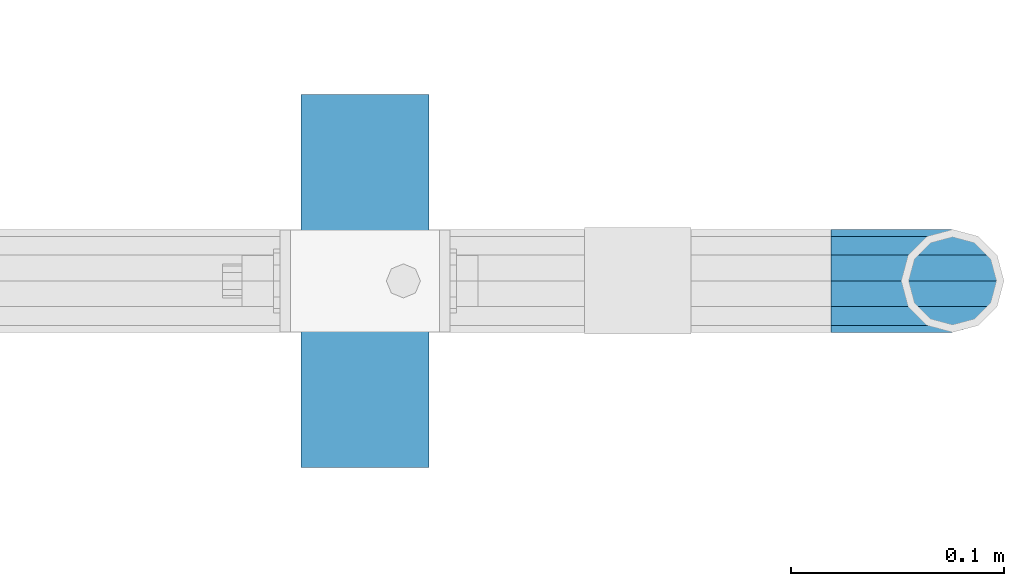
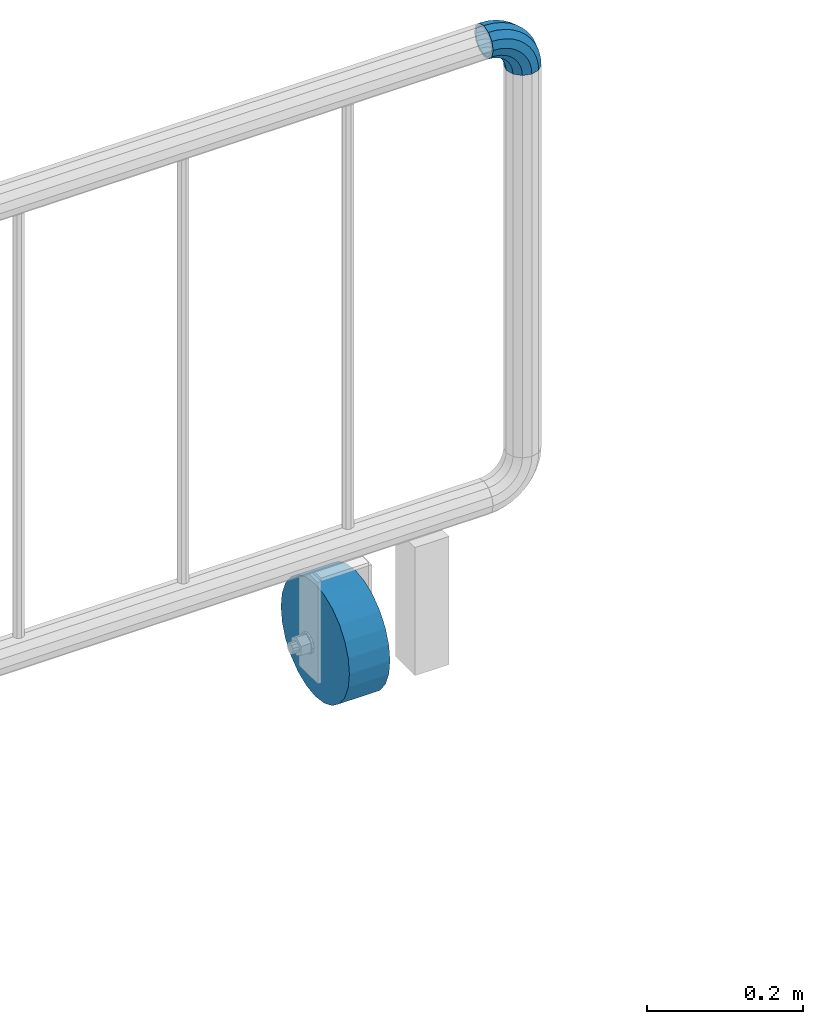
# One storey, part 152 of 208: 1 beam, 1 member.
"""IFC2X3 building model written with IfcOpenShell, lengths in millimetres."""

from ifc_helpers import new_model, si_unit, frame, origin_with_axes, place, context, subcontext, project, spatial, faceted_brep, material, type_object, element, save


model = new_model("IFC2X3")

# Units and contexts
model_context = context("Model", 3, precision=1e-05, world=origin_with_axes())
body_context = subcontext(model_context, "Body", "Model", "MODEL_VIEW")
ifc_project = project(units=[si_unit("LENGTHUNIT", "METRE", prefix="MILLI"), si_unit("AREAUNIT", "SQUARE_METRE"), si_unit("VOLUMEUNIT", "CUBIC_METRE"), si_unit("MASSUNIT", "GRAM", prefix="KILO"), si_unit("TIMEUNIT", "SECOND"), si_unit("PLANEANGLEUNIT", "RADIAN"), si_unit("SOLIDANGLEUNIT", "STERADIAN"), si_unit("THERMODYNAMICTEMPERATUREUNIT", "DEGREE_CELSIUS"), si_unit("LUMINOUSINTENSITYUNIT", "LUMEN")], contexts=[model_context])

# Site, building, storey
site_placement = place(None, origin_with_axes())
site = spatial("IfcSite", under=ifc_project, at=site_placement, CompositionType="ELEMENT")
building_placement = place(site_placement, origin_with_axes())
building = spatial("IfcBuilding", under=site, at=building_placement, Name="Standard", CompositionType="ELEMENT")
storey_placement = place(building_placement, origin_with_axes())
storey = spatial("IfcBuildingStorey", under=building, at=storey_placement, Name="Undefined", CompositionType="ELEMENT", Elevation=0.0)

# Member
ifc_material_1 = material()
member_type = type_object("IfcMemberType", PredefinedType="NOTDEFINED")
member_placement = place(storey_placement, frame((-12177.0539762199, 5941.85399999618, 935.350000000009), z_axis=(0.0, -1.0, 0.0), x_axis=(0.707106781186548, 0.0, -0.707106781186548)))
element("IfcMember", 1, at=member_placement, inside=storey, type_object=member_type, material=ifc_material_1, context=body_context, shape_type="Brep", body=[
    faceted_brep([(17.0766287656552, -17.0766287656552, 0.0), (14.7887943220539, -14.7887943220539, -12.0749999999998), (19.0945697419538, -11.1113146999724, -12.0749999999998), (20.9963409898282, -13.7288782624146, 0.0), (8.53831438282759, -8.53831438282759, -20.9145135013941), (13.8988340683954, -3.95999805533756, -20.9145135013941), (0.0, 0.0, -24.1500000000001), (6.80132714696265, 5.80888215173945, -24.1500000000001), (-8.53831438282759, 8.53831438282759, -20.9145135013941), (-0.296179774470147, 15.5777623588165, -20.9145135013941), (-14.7887943220521, 14.7887943220521, -12.0749999999998), (-5.49191544802852, 22.7290790034513, -12.0749999999998), (-17.0766287656552, 17.0766287656552, 0.0), (-7.39368669589931, 25.3466425658935, 0.0), (-14.7887943220521, 14.7887943220521, 12.0749999999998), (-5.49191544802852, 22.7290790034513, 12.0749999999998), (-8.53831438282759, 8.53831438282759, 20.9145135013941), (-0.296179774470147, 15.5777623588165, 20.9145135013941), (0.0, 0.0, 24.1500000000001), (6.80132714696265, 5.80888215173945, 24.1500000000001), (8.53831438282759, -8.53831438282759, 20.9145135013941), (13.8988340683954, -3.95999805533756, 20.9145135013941), (14.7887943220539, -14.7887943220539, 12.0749999999998), (19.0945697419538, -11.1113146999724, 12.0749999999998), (14.5310443533836, -14.5310443533836, 0.0), (12.5842535535485, -12.5842535535485, 10.2750000000001), (17.2620366843166, -8.58904933077247, 10.2750000000001), (18.8803140815726, -10.8164170826676, 0.0), (7.26552217669268, -7.26552217669268, 17.7968220477701), (12.8408206142685, -2.50376746546499, 17.7968220477701), (0.0, 0.0, 20.5500000000002), (6.80132714696265, 5.80888215173945, 20.5500000000002), (-7.26552217669087, 7.26552217669087, 17.7968220477701), (0.761833679658594, 14.1215317689421, 17.7968220477701), (-12.5842535535485, 12.5842535535485, 10.2750000000001), (-3.65938239039133, 20.2068136342514, 10.2750000000001), (-14.5310443533836, 14.5310443533836, 0.0), (-5.27765978764546, 22.4341813861447, 0.0), (-12.5842535535485, 12.5842535535485, -10.2750000000001), (-3.65938239039133, 20.2068136342514, -10.2750000000001), (-7.26552217669087, 7.26552217669087, -17.7968220477701), (0.761833679658594, 14.1215317689421, -17.7968220477701), (0.0, 0.0, -20.5500000000002), (6.80132714696265, 5.80888215173945, -20.5500000000002), (7.26552217669268, -7.26552217669268, -17.7968220477701), (12.8408206142685, -2.50376746546499, -17.7968220477701), (12.5842535535485, -12.5842535535485, -10.2750000000001), (17.2620366843166, -8.58904933077247, -10.2750000000001), (23.9226184787876, -8.15268262886457, -12.0749999999998), (25.3914986111904, -11.0355222080452, 0.0), (19.9095633268353, -0.27661842847192, -20.9145135013941), (14.4276280424801, 10.482285351105, -24.1500000000001), (8.94569275812501, 21.2411891306783, -20.9145135013941), (4.93263760617265, 29.117253331071, -12.0749999999998), (3.46375747377169, 32.0000929102534, 0.0), (4.93263760617265, 29.117253331071, 12.0749999999998), (8.94569275812501, 21.2411891306783, 20.9145135013941), (14.4276280424801, 10.482285351105, 24.1500000000001), (19.9095633268353, -0.27661842847192, 20.9145135013941), (23.9226184787876, -8.15268262886457, 12.0749999999998), (22.5072161777225, -5.3747992032786, 10.2750000000001), (23.7571328121267, -7.82789872096691, 0.0), (19.0923804273043, 1.32719331506814, 17.7968220477701), (14.4276280424801, 10.482285351105, 20.5500000000002), (9.76287565765597, 19.6373773871383, 17.7968220477701), (6.34803990723776, 26.3393699054886, 10.2750000000001), (5.0981232728318, 28.7924694231751, 0.0), (6.34803990723776, 26.3393699054886, -10.2750000000001), (9.76287565765597, 19.6373773871383, -17.7968220477701), (14.4276280424801, 10.482285351105, -20.5500000000002), (19.0923804273043, 1.32719331506814, -17.7968220477701), (22.5072161777225, -5.3747992032786, -10.2750000000001), (29.1540579492776, -5.98574944945176, -12.0749999999998), (30.1538782624175, -9.06287996733772, 0.0), (26.422498055339, 2.42112746692692, -20.9145135013941), (22.6911178482624, 13.9051349011897, -24.1500000000001), (18.9597376411857, 25.3891423354562, -20.9145135013941), (16.2281777472472, 33.7960192518349, -12.0749999999998), (15.2283574341091, 36.873149769719, 0.0), (16.2281777472472, 33.7960192518349, 12.0749999999998), (18.9597376411857, 25.3891423354562, 20.9145135013941), (22.6911178482624, 13.9051349011897, 24.1500000000001), (26.422498055339, 2.42112746692692, 20.9145135013941), (29.1540579492776, -5.98574944945176, 12.0749999999998), (28.1906383068908, -3.0206486766856, 10.2750000000001), (29.041417082668, -5.63907650867441, 0.0), (25.8662674654661, 4.13302919625858, 17.7968220477701), (22.6911178482624, 13.9051349011897, 20.5500000000002), (19.5159682310605, 23.6772406061227, 17.7968220477701), (17.1915973896339, 30.8309184790687, 10.2750000000001), (16.3408186138568, 33.4493463110575, 0.0), (17.1915973896339, 30.8309184790687, -10.2750000000001), (19.5159682310605, 23.6772406061227, -17.7968220477701), (22.6911178482624, 13.9051349011897, -20.5500000000002), (25.8662674654661, 4.13302919625858, -17.7968220477701), (28.1906383068908, -3.0206486766856, -10.2750000000001), (34.660072751507, -4.66387224825667, -12.0749999999998), (35.1662143510621, -7.85952453908249, 0.0), (33.2772681857005, 4.06681217360347, -20.9145135013941), (31.3883220203406, 15.9931488862876, -24.1500000000001), (29.4993758549808, 27.9194855989754, -20.9145135013941), (28.1165712891743, 36.6501700208355, -12.0749999999998), (27.6104296896192, 39.8458223116613, 0.0), (28.1165712891743, 36.6501700208355, 12.0749999999998), (29.4993758549808, 27.9194855989754, 20.9145135013941), (31.3883220203406, 15.9931488862876, 24.1500000000001), (33.2772681857005, 4.06681217360347, 20.9145135013941), (34.660072751507, -4.66387224825667, 12.0749999999998), (34.1723583568, -1.58456474993909, 10.2750000000001), (34.6030502769172, -4.30384651293934, 0.0), (32.995686148628, 5.84465118667504, 17.7968220477701), (31.3883220203406, 15.9931488862876, 20.5500000000002), (29.7809578920533, 26.1416465859038, 17.7968220477701), (28.6042856838831, 33.5708625225197, 10.2750000000001), (28.1735937637659, 36.29014428552, 0.0), (28.6042856838831, 33.5708625225197, -10.2750000000001), (29.7809578920533, 26.1416465859038, -17.7968220477701), (31.3883220203406, 15.9931488862876, -20.5500000000002), (32.995686148628, 5.84465118667504, -17.7968220477701), (34.1723583568, -1.58456474993909, -10.2750000000001), (40.3050865276346, -4.21960002902779, -12.0749999999998), (40.3050865276346, -7.45508652763237, 0.0), (40.3050865276327, 4.61991347236653, -20.9145135013941), (40.3050865276327, 16.6949134723673, -24.1500000000001), (40.3050865276346, 28.7699134723662, -20.9145135013941), (40.3050865276346, 37.6094269737623, -12.0749999999998), (40.3050865276346, 40.8449134723669, 0.0), (40.3050865276346, 37.6094269737623, 12.0749999999998), (40.3050865276346, 28.7699134723662, 20.9145135013941), (40.3050865276327, 16.6949134723673, 24.1500000000001), (40.3050865276327, 4.61991347236653, 20.9145135013941), (40.3050865276346, -4.21960002902779, 12.0749999999998), (40.3050865276327, -1.10190857540329, 10.2750000000001), (40.3050865276346, -3.85508652763383, 0.0), (40.3050865276346, 6.41991347236763, 17.7968220477701), (40.3050865276327, 16.6949134723673, 20.5500000000002), (40.3050865276346, 26.9699134723669, 17.7968220477701), (40.3050865276346, 34.491735520136, 10.2750000000001), (40.3050865276327, 37.2449134723665, 0.0), (40.3050865276346, 34.491735520136, -10.2750000000001), (40.3050865276346, 26.9699134723669, -17.7968220477701), (40.3050865276327, 16.6949134723673, -20.5500000000002), (40.3050865276346, 6.41991347236763, -17.7968220477701), (40.3050865276327, -1.10190857540329, -10.2750000000001), (45.9501003037603, -4.66387224825485, -12.0749999999998), (45.4439587042052, -7.8595245390843, 0.0), (47.3329048695668, 4.06681217360529, -20.9145135013941), (49.2218510349267, 15.9931488862894, -24.1500000000001), (51.1107972002883, 27.9194855989754, -20.9145135013941), (52.4936017660948, 36.6501700208355, -12.0749999999998), (52.9997433656481, 39.8458223116631, 0.0), (52.4936017660948, 36.6501700208355, 12.0749999999998), (51.1107972002883, 27.9194855989754, 20.9145135013941), (49.2218510349267, 15.9931488862894, 24.1500000000001), (47.3329048695668, 4.06681217360529, 20.9145135013941), (45.9501003037603, -4.66387224825485, 12.0749999999998), (46.4378146984691, -1.58456474993909, 10.2750000000001), (46.0071227783501, -4.30384651294116, 0.0), (47.6144869066393, 5.84465118667322, 17.7968220477701), (49.2218510349267, 15.9931488862894, 20.5500000000002), (50.8292151632158, 26.1416465859038, 17.7968220477701), (52.0058873713861, 33.5708625225197, 10.2750000000001), (52.4365792915032, 36.29014428552, 0.0), (52.0058873713861, 33.5708625225197, -10.2750000000001), (50.8292151632158, 26.1416465859038, -17.7968220477701), (49.2218510349267, 15.9931488862894, -20.5500000000002), (47.6144869066393, 5.84465118667322, -17.7968220477701), (46.4378146984691, -1.58456474993909, -10.2750000000001), (51.4561151059897, -5.98574944945358, -12.0749999999998), (50.4562947928516, -9.06287996733772, 0.0), (54.1876749999301, 2.42112746692692, -20.9145135013941), (57.9190552070068, 13.9051349011897, -24.1500000000001), (61.6504354140834, 25.3891423354562, -20.9145135013941), (64.3819953080219, 33.7960192518349, -12.0749999999998), (65.3818156211601, 36.873149769719, 0.0), (64.3819953080219, 33.7960192518349, 12.0749999999998), (61.6504354140834, 25.3891423354562, 20.9145135013941), (57.9190552070068, 13.9051349011897, 24.1500000000001), (54.1876749999301, 2.42112746692692, 20.9145135013941), (51.4561151059897, -5.98574944945358, 12.0749999999998), (52.4195347483783, -3.0206486766856, 10.2750000000001), (51.5687559726011, -5.63907650867441, 0.0), (54.743905589803, 4.13302919625858, 17.7968220477701), (57.9190552070068, 13.9051349011897, 20.5500000000002), (61.0942048242086, 23.6772406061227, 17.7968220477701), (63.4185756656334, 30.8309184790669, 10.2750000000001), (64.2693544414105, 33.4493463110557, 0.0), (63.4185756656334, 30.8309184790669, -10.2750000000001), (61.0942048242086, 23.6772406061227, -17.7968220477701), (57.9190552070068, 13.9051349011897, -20.5500000000002), (54.743905589803, 4.13302919625858, -17.7968220477701), (52.4195347483783, -3.0206486766856, -10.2750000000001), (56.6875545764815, -8.15268262886457, -12.0749999999998), (55.2186744440787, -11.0355222080452, 0.0), (60.7006097284338, -0.27661842847192, -20.9145135013941), (66.182545012789, 10.482285351105, -24.1500000000001), (71.6644802971441, 21.2411891306783, -20.9145135013941), (75.6775354490965, 29.117253331071, -12.0749999999998), (77.1464155814974, 32.0000929102534, 0.0), (75.6775354490965, 29.117253331071, 12.0749999999998), (71.6644802971441, 21.2411891306783, 20.9145135013941), (66.182545012789, 10.482285351105, 24.1500000000001), (60.7006097284338, -0.27661842847192, 20.9145135013941), (56.6875545764815, -8.15268262886457, 12.0749999999998), (58.1029568775466, -5.3747992032786, 10.2750000000001), (56.8530402431425, -7.82789872096691, 0.0), (61.5177926279648, 1.32719331506814, 17.7968220477701), (66.182545012789, 10.482285351105, 20.5500000000002), (70.8472973976113, 19.6373773871401, 17.7968220477701), (74.2621331480332, 26.3393699054868, 10.2750000000001), (75.5120497824355, 28.7924694231733, 0.0), (74.2621331480332, 26.3393699054868, -10.2750000000001), (70.8472973976113, 19.6373773871401, -17.7968220477701), (66.182545012789, 10.482285351105, -20.5500000000002), (61.5177926279648, 1.32719331506814, -17.7968220477701), (58.1029568775466, -5.3747992032786, -10.2750000000001), (61.5156033133135, -11.1113146999742, -12.0749999999998), (59.6138320654427, -13.7288782624164, 0.0), (66.7113389868737, -3.95999805533756, -20.9145135013941), (73.8088459083046, 5.80888215173763, -24.1500000000001), (80.9063528297374, 15.5777623588183, -20.9145135013941), (86.1020885032976, 22.7290790034513, -12.0749999999998), (88.0038597511684, 25.3466425658935, 0.0), (86.1020885032976, 22.7290790034513, 12.0749999999998), (80.9063528297374, 15.5777623588183, 20.9145135013941), (73.8088459083046, 5.80888215173763, 24.1500000000001), (66.7113389868737, -3.95999805533756, 20.9145135013941), (61.5156033133135, -11.1113146999742, 12.0749999999998), (63.3481363709525, -8.58904933077247, 10.2750000000001), (61.7298589736947, -10.8164170826658, 0.0), (67.7693524409988, -2.50376746546317, 17.7968220477701), (73.8088459083046, 5.80888215173763, 20.5500000000002), (79.8483393756105, 14.1215317689421, 17.7968220477701), (84.2695554456586, 20.2068136342532, 10.2750000000001), (85.8878328429146, 22.4341813861447, 0.0), (84.2695554456586, 20.2068136342532, -10.2750000000001), (79.8483393756105, 14.1215317689421, -17.7968220477701), (73.8088459083046, 5.80888215173763, -20.5500000000002), (67.7693524409988, -2.50376746546317, -17.7968220477701), (63.3481363709525, -8.58904933077247, -10.2750000000001), (65.8213787332152, -14.7887943220539, -12.0749999999998), (63.5335442896121, -17.0766287656534, 0.0), (72.0718586724379, -8.53831438282759, -20.9145135013941), (80.6101730552673, 1.81898940354586e-12, -24.1500000000001), (89.1484874380967, 8.53831438282759, -20.9145135013941), (95.3989673773231, 14.7887943220539, -12.0749999999998), (97.6868018209225, 17.0766287656534, 0.0), (95.3989673773231, 14.7887943220539, 12.0749999999998), (89.1484874380967, 8.53831438282759, 20.9145135013941), (80.6101730552673, 1.81898940354586e-12, 24.1500000000001), (72.0718586724379, -8.53831438282759, 20.9145135013941), (65.8213787332152, -14.7887943220539, 12.0749999999998), (68.0259195017188, -12.5842535535503, 10.2750000000001), (66.0791287018856, -14.5310443533836, 0.0), (73.3446508785764, -7.26552217669268, 17.7968220477701), (80.6101730552673, 1.81898940354586e-12, 20.5500000000002), (87.8756952319582, 7.26552217669268, 17.7968220477701), (93.1944266088158, 12.5842535535503, 10.2750000000001), (95.141217408649, 14.5310443533836, 0.0), (93.1944266088158, 12.5842535535503, -10.2750000000001), (87.8756952319582, 7.26552217669268, -17.7968220477701), (80.6101730552673, 1.81898940354586e-12, -20.5500000000002), (73.3446508785764, -7.26552217669268, -17.7968220477701), (68.0259195017188, -12.5842535535503, -10.2750000000001)], [[[0, 1, 2, 3]], [[1, 4, 5, 2]], [[4, 6, 7, 5]], [[6, 8, 9, 7]], [[8, 10, 11, 9]], [[10, 12, 13, 11]], [[12, 14, 15, 13]], [[14, 16, 17, 15]], [[16, 18, 19, 17]], [[18, 20, 21, 19]], [[20, 22, 23, 21]], [[22, 0, 3, 23]], [[24, 25, 26, 27]], [[25, 28, 29, 26]], [[28, 30, 31, 29]], [[30, 32, 33, 31]], [[32, 34, 35, 33]], [[34, 36, 37, 35]], [[36, 38, 39, 37]], [[38, 40, 41, 39]], [[40, 42, 43, 41]], [[42, 44, 45, 43]], [[44, 46, 47, 45]], [[46, 24, 27, 47]], [[22, 20, 18, 16, 14, 12, 10, 8, 6, 4, 1, 0], [46, 44, 42, 40, 38, 36, 34, 32, 30, 28, 25, 24]], [[3, 2, 48, 49]], [[2, 5, 50, 48]], [[5, 7, 51, 50]], [[7, 9, 52, 51]], [[9, 11, 53, 52]], [[11, 13, 54, 53]], [[13, 15, 55, 54]], [[15, 17, 56, 55]], [[17, 19, 57, 56]], [[19, 21, 58, 57]], [[21, 23, 59, 58]], [[23, 3, 49, 59]], [[27, 26, 60, 61]], [[26, 29, 62, 60]], [[29, 31, 63, 62]], [[31, 33, 64, 63]], [[33, 35, 65, 64]], [[35, 37, 66, 65]], [[37, 39, 67, 66]], [[39, 41, 68, 67]], [[41, 43, 69, 68]], [[43, 45, 70, 69]], [[45, 47, 71, 70]], [[47, 27, 61, 71]], [[49, 48, 72, 73]], [[48, 50, 74, 72]], [[50, 51, 75, 74]], [[51, 52, 76, 75]], [[52, 53, 77, 76]], [[53, 54, 78, 77]], [[54, 55, 79, 78]], [[55, 56, 80, 79]], [[56, 57, 81, 80]], [[57, 58, 82, 81]], [[58, 59, 83, 82]], [[59, 49, 73, 83]], [[61, 60, 84, 85]], [[60, 62, 86, 84]], [[62, 63, 87, 86]], [[63, 64, 88, 87]], [[64, 65, 89, 88]], [[65, 66, 90, 89]], [[66, 67, 91, 90]], [[67, 68, 92, 91]], [[68, 69, 93, 92]], [[69, 70, 94, 93]], [[70, 71, 95, 94]], [[71, 61, 85, 95]], [[73, 72, 96, 97]], [[72, 74, 98, 96]], [[74, 75, 99, 98]], [[75, 76, 100, 99]], [[76, 77, 101, 100]], [[77, 78, 102, 101]], [[78, 79, 103, 102]], [[79, 80, 104, 103]], [[80, 81, 105, 104]], [[81, 82, 106, 105]], [[82, 83, 107, 106]], [[83, 73, 97, 107]], [[85, 84, 108, 109]], [[84, 86, 110, 108]], [[86, 87, 111, 110]], [[87, 88, 112, 111]], [[88, 89, 113, 112]], [[89, 90, 114, 113]], [[90, 91, 115, 114]], [[91, 92, 116, 115]], [[92, 93, 117, 116]], [[93, 94, 118, 117]], [[94, 95, 119, 118]], [[95, 85, 109, 119]], [[97, 96, 120, 121]], [[96, 98, 122, 120]], [[98, 99, 123, 122]], [[99, 100, 124, 123]], [[100, 101, 125, 124]], [[101, 102, 126, 125]], [[102, 103, 127, 126]], [[103, 104, 128, 127]], [[104, 105, 129, 128]], [[105, 106, 130, 129]], [[106, 107, 131, 130]], [[107, 97, 121, 131]], [[109, 108, 132, 133]], [[108, 110, 134, 132]], [[110, 111, 135, 134]], [[111, 112, 136, 135]], [[112, 113, 137, 136]], [[113, 114, 138, 137]], [[114, 115, 139, 138]], [[115, 116, 140, 139]], [[116, 117, 141, 140]], [[117, 118, 142, 141]], [[118, 119, 143, 142]], [[119, 109, 133, 143]], [[121, 120, 144, 145]], [[120, 122, 146, 144]], [[122, 123, 147, 146]], [[123, 124, 148, 147]], [[124, 125, 149, 148]], [[125, 126, 150, 149]], [[126, 127, 151, 150]], [[127, 128, 152, 151]], [[128, 129, 153, 152]], [[129, 130, 154, 153]], [[130, 131, 155, 154]], [[131, 121, 145, 155]], [[133, 132, 156, 157]], [[132, 134, 158, 156]], [[134, 135, 159, 158]], [[135, 136, 160, 159]], [[136, 137, 161, 160]], [[137, 138, 162, 161]], [[138, 139, 163, 162]], [[139, 140, 164, 163]], [[140, 141, 165, 164]], [[141, 142, 166, 165]], [[142, 143, 167, 166]], [[143, 133, 157, 167]], [[145, 144, 168, 169]], [[144, 146, 170, 168]], [[146, 147, 171, 170]], [[147, 148, 172, 171]], [[148, 149, 173, 172]], [[149, 150, 174, 173]], [[150, 151, 175, 174]], [[151, 152, 176, 175]], [[152, 153, 177, 176]], [[153, 154, 178, 177]], [[154, 155, 179, 178]], [[155, 145, 169, 179]], [[157, 156, 180, 181]], [[156, 158, 182, 180]], [[158, 159, 183, 182]], [[159, 160, 184, 183]], [[160, 161, 185, 184]], [[161, 162, 186, 185]], [[162, 163, 187, 186]], [[163, 164, 188, 187]], [[164, 165, 189, 188]], [[165, 166, 190, 189]], [[166, 167, 191, 190]], [[167, 157, 181, 191]], [[169, 168, 192, 193]], [[168, 170, 194, 192]], [[170, 171, 195, 194]], [[171, 172, 196, 195]], [[172, 173, 197, 196]], [[173, 174, 198, 197]], [[174, 175, 199, 198]], [[175, 176, 200, 199]], [[176, 177, 201, 200]], [[177, 178, 202, 201]], [[178, 179, 203, 202]], [[179, 169, 193, 203]], [[181, 180, 204, 205]], [[180, 182, 206, 204]], [[182, 183, 207, 206]], [[183, 184, 208, 207]], [[184, 185, 209, 208]], [[185, 186, 210, 209]], [[186, 187, 211, 210]], [[187, 188, 212, 211]], [[188, 189, 213, 212]], [[189, 190, 214, 213]], [[190, 191, 215, 214]], [[191, 181, 205, 215]], [[193, 192, 216, 217]], [[192, 194, 218, 216]], [[194, 195, 219, 218]], [[195, 196, 220, 219]], [[196, 197, 221, 220]], [[197, 198, 222, 221]], [[198, 199, 223, 222]], [[199, 200, 224, 223]], [[200, 201, 225, 224]], [[201, 202, 226, 225]], [[202, 203, 227, 226]], [[203, 193, 217, 227]], [[205, 204, 228, 229]], [[204, 206, 230, 228]], [[206, 207, 231, 230]], [[207, 208, 232, 231]], [[208, 209, 233, 232]], [[209, 210, 234, 233]], [[210, 211, 235, 234]], [[211, 212, 236, 235]], [[212, 213, 237, 236]], [[213, 214, 238, 237]], [[214, 215, 239, 238]], [[215, 205, 229, 239]], [[217, 216, 240, 241]], [[216, 218, 242, 240]], [[218, 219, 243, 242]], [[219, 220, 244, 243]], [[220, 221, 245, 244]], [[221, 222, 246, 245]], [[222, 223, 247, 246]], [[223, 224, 248, 247]], [[224, 225, 249, 248]], [[225, 226, 250, 249]], [[226, 227, 251, 250]], [[227, 217, 241, 251]], [[229, 228, 252, 253]], [[228, 230, 254, 252]], [[230, 231, 255, 254]], [[231, 232, 256, 255]], [[232, 233, 257, 256]], [[233, 234, 258, 257]], [[234, 235, 259, 258]], [[235, 236, 260, 259]], [[236, 237, 261, 260]], [[237, 238, 262, 261]], [[238, 239, 263, 262]], [[239, 229, 253, 263]], [[242, 243, 244, 245, 246, 247, 248, 249, 250, 251, 241, 240], [254, 255, 256, 257, 258, 259, 260, 261, 262, 263, 253, 252]]]),
])

# Beam
ifc_material_2 = material()
beam_type = type_object("IfcBeamType", PredefinedType="NOTDEFINED")
beam_placement = place(storey_placement, frame((-12365.9039762196, 5941.85399999618, 87.5000130887838), z_axis=(0.0, 0.0, 1.0), x_axis=(-1.0, 0.0, 0.0)))
element("IfcBeam", 2, at=beam_placement, inside=storey, type_object=beam_type, material=ifc_material_2, context=body_context, shape_type="Brep", body=[
    faceted_brep([(0.0, -87.5, 0.0), (0.0, -84.5185098002935, -22.6466664464706), (60.0, -84.5185098002935, -22.6466664464706), (60.0, -87.5, 0.0), (0.0, -75.7772228311383, -43.75), (60.0, -75.7772228311383, -43.75), (0.0, -61.8718433538229, -61.8718433538229), (60.0, -61.8718433538229, -61.8718433538229), (0.0, -43.75, -75.7772228311384), (60.0, -43.75, -75.7772228311384), (0.0, -22.6466664464706, -84.5185098002935), (60.0, -22.6466664464706, -84.5185098002935), (0.0, 0.0, -87.5), (60.0, 0.0, -87.5), (0.0, 22.6466664464706, -84.5185098002935), (60.0, 22.6466664464706, -84.5185098002935), (0.0, 43.75, -75.7772228311384), (60.0, 43.75, -75.7772228311384), (0.0, 61.8718433538229, -61.8718433538229), (60.0, 61.8718433538229, -61.8718433538229), (0.0, 75.7772228311383, -43.75), (60.0, 75.7772228311383, -43.75), (0.0, 84.5185098002935, -22.6466664464705), (60.0, 84.5185098002935, -22.6466664464705), (0.0, 87.5, 1.4210854715202e-14), (60.0, 87.5, 1.4210854715202e-14), (0.0, 84.5185098002935, 22.6466664464706), (60.0, 84.5185098002935, 22.6466664464706), (0.0, 75.7772228311383, 43.75), (60.0, 75.7772228311383, 43.75), (0.0, 61.8718433538229, 61.8718433538229), (60.0, 61.8718433538229, 61.8718433538229), (0.0, 43.75, 75.7772228311384), (60.0, 43.75, 75.7772228311384), (0.0, 22.6466664464706, 84.5185098002935), (60.0, 22.6466664464706, 84.5185098002935), (0.0, 0.0, 87.5), (60.0, 0.0, 87.5), (0.0, -22.6466664464706, 84.5185098002935), (60.0, -22.6466664464706, 84.5185098002935), (0.0, -43.75, 75.7772228311384), (60.0, -43.75, 75.7772228311384), (0.0, -61.8718433538229, 61.8718433538229), (60.0, -61.8718433538229, 61.8718433538229), (0.0, -75.7772228311383, 43.75), (60.0, -75.7772228311383, 43.75), (0.0, -84.5185098002935, 22.6466664464706), (60.0, -84.5185098002935, 22.6466664464706)], [[[0, 1, 2, 3]], [[1, 4, 5, 2]], [[4, 6, 7, 5]], [[6, 8, 9, 7]], [[8, 10, 11, 9]], [[10, 12, 13, 11]], [[12, 14, 15, 13]], [[14, 16, 17, 15]], [[16, 18, 19, 17]], [[18, 20, 21, 19]], [[20, 22, 23, 21]], [[22, 24, 25, 23]], [[24, 26, 27, 25]], [[26, 28, 29, 27]], [[28, 30, 31, 29]], [[30, 32, 33, 31]], [[32, 34, 35, 33]], [[34, 36, 37, 35]], [[36, 38, 39, 37]], [[38, 40, 41, 39]], [[40, 42, 43, 41]], [[42, 44, 45, 43]], [[44, 46, 47, 45]], [[46, 0, 3, 47]], [[5, 7, 9, 11, 13, 15, 17, 19, 21, 23, 25, 27, 29, 31, 33, 35, 37, 39, 41, 43, 45, 47, 3, 2]], [[46, 44, 42, 40, 38, 36, 34, 32, 30, 28, 26, 24, 22, 20, 18, 16, 14, 12, 10, 8, 6, 4, 1, 0]]]),
])

save(model, "model.ifc")
